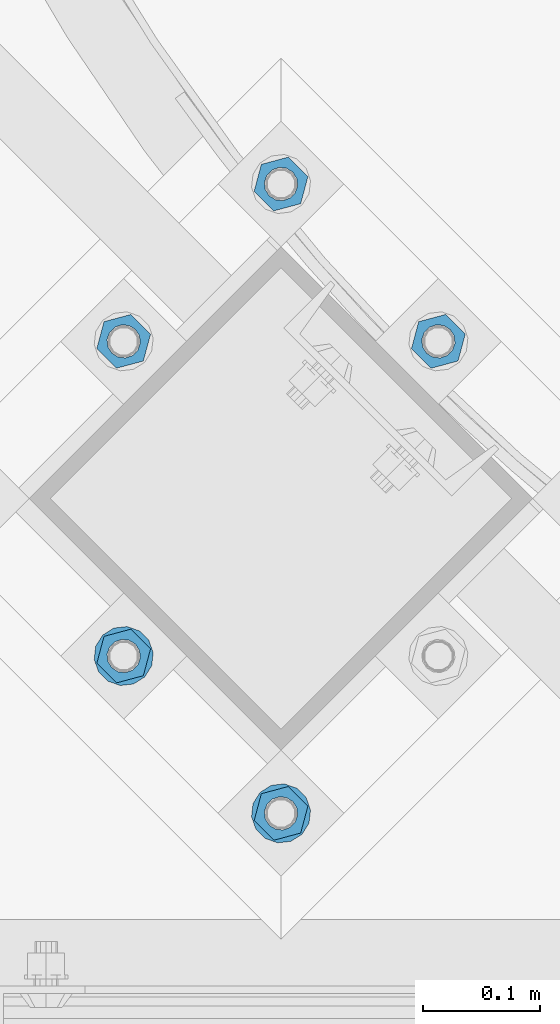
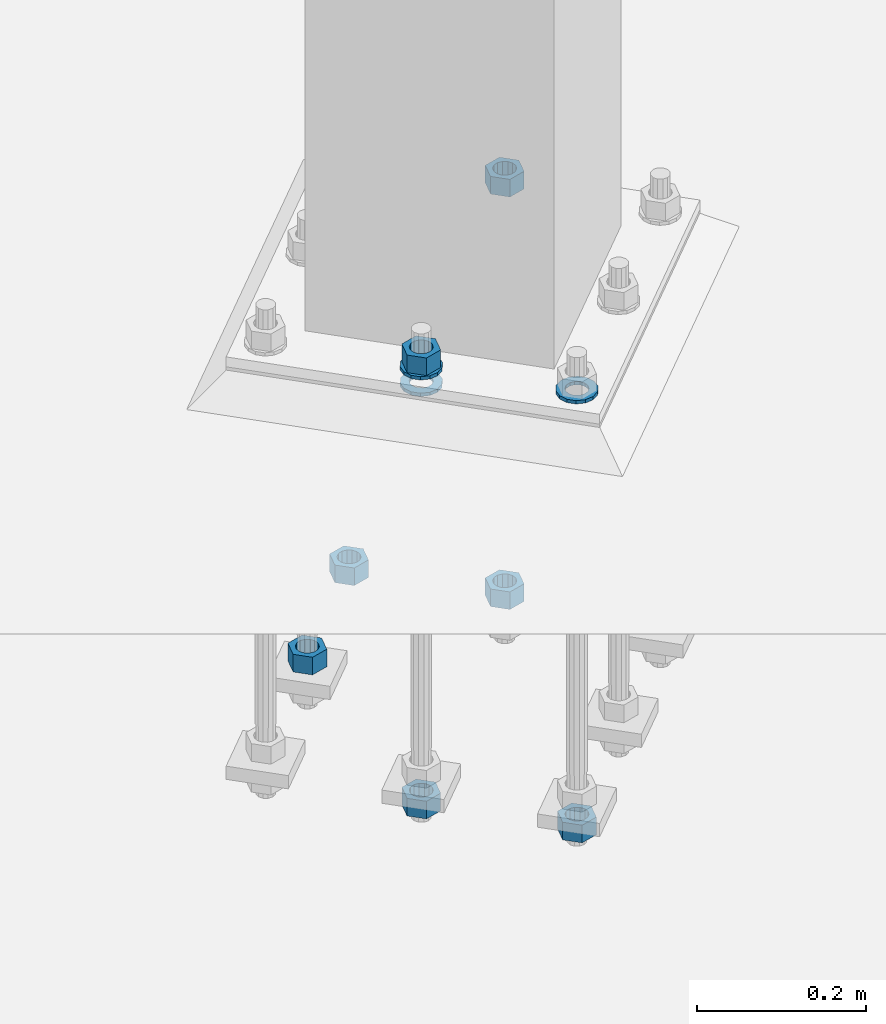
# One storey, part 863 of 1876: 10 columns, 1 element without a shape of its own.
"""IFC2X3 building model written with IfcOpenShell, lengths in millimetres."""

from ifc_helpers import new_model, si_unit, frame, origin_with_axes, place, context, subcontext, project, spatial, faceted_brep, material, type_object, element, aggregate, save


model = new_model("IFC2X3")

# Units and contexts
model_context = context("Model", 3, precision=1e-05, world=origin_with_axes())
body_context = subcontext(model_context, "Body", "Model", "MODEL_VIEW")
ifc_project = project(units=[si_unit("LENGTHUNIT", "METRE", prefix="MILLI"), si_unit("AREAUNIT", "SQUARE_METRE"), si_unit("VOLUMEUNIT", "CUBIC_METRE"), si_unit("MASSUNIT", "GRAM", prefix="KILO"), si_unit("TIMEUNIT", "SECOND"), si_unit("PLANEANGLEUNIT", "RADIAN"), si_unit("SOLIDANGLEUNIT", "STERADIAN"), si_unit("THERMODYNAMICTEMPERATUREUNIT", "DEGREE_CELSIUS"), si_unit("LUMINOUSINTENSITYUNIT", "LUMEN")], contexts=[model_context])

# Site, building, storey
site_placement = place(None, origin_with_axes())
site = spatial("IfcSite", under=ifc_project, at=site_placement, CompositionType="ELEMENT")
building_placement = place(site_placement, origin_with_axes())
building = spatial("IfcBuilding", under=site, at=building_placement, Name="Undefined", CompositionType="ELEMENT")
storey_placement = place(building_placement, origin_with_axes())
storey = spatial("IfcBuildingStorey", under=building, at=storey_placement, Name="Undefined", CompositionType="ELEMENT", Elevation=0.0)

# Assembly, columns
assembly_placement = place(storey_placement, origin_with_axes())
assembly = element("IfcElementAssembly", 1, at=assembly_placement, inside=storey, Name="TEMPLATE", AssemblyPlace="NOTDEFINED", PredefinedType="RIGID_FRAME")
ifc_material_1 = material(Name="STEEL/A563")
column_type_1 = type_object("IfcColumnType", Name="1_HEAVY_HEX_NUT", PredefinedType="NOTDEFINED")
column_1_placement = place(assembly_placement, frame((3917.62601588861, -14852.9739841119, -508.0), z_axis=(0.707106781186548, 0.707106781186547, 0.0), x_axis=(0.0, 0.0, -1.0)))
column_1 = element("IfcColumn", 2, at=column_1_placement, type_object=column_type_1, material=ifc_material_1, Name="NUT", ObjectType="1_HEAVY_HEX_NUT", context=body_context, shape_type="Brep", body=[
    faceted_brep([(0.0, -23.8099994659442, 9.09494701772928e-13), (0.0, -11.9099998474121, -20.6200008392352), (25.4, -11.9099998474157, -20.6200008392361), (25.4, -23.8099994659478, 0.0), (0.0, 11.9099998474157, -20.620000839237), (25.4, 11.9099998474121, -20.620000839237), (0.0, 23.8099994659478, 9.09494701772928e-13), (25.4, 23.8099994659442, 0.0), (0.0, 11.9099998474157, 20.620000839237), (25.4, 11.9099998474121, 20.620000839237), (0.0, -11.9099998474121, 20.6200008392389), (25.4, -11.9099998474157, 20.6200008392379), (0.0, 1.81898940354586e-12, 14.2899999618567), (0.0, 6.20019861543915, 12.8748450879584), (25.4, 6.20019861543733, 12.8748450879593), (25.4, 0.0, 14.2899999618558), (0.0, 11.1723718546473, 8.90966924477925), (25.4, 11.1723718546436, 8.90966924477925), (0.0, 13.9317198278914, 3.17982413774916), (25.4, 13.9317198278877, 3.17982413775007), (0.0, 13.9317198278914, -3.17982413774644), (25.4, 13.9317198278895, -3.17982413774735), (0.0, 11.1723718546473, -8.90966924477834), (25.4, 11.1723718546455, -8.90966924477925), (0.0, 6.20019861544279, -12.8748450879575), (25.4, 6.20019861543915, -12.8748450879584), (0.0, 3.63797880709171e-12, -14.2899999618548), (25.4, -3.63797880709171e-12, -14.2899999618548), (0.0, -6.20019861543733, -12.8748450879566), (25.4, -6.20019861544097, -12.8748450879584), (0.0, -11.1723718546455, -8.90966924477743), (25.4, -11.1723718546473, -8.90966924477834), (0.0, -13.9317198278877, -3.17982413774735), (25.4, -13.9317198278914, -3.17982413774826), (0.0, -13.9317198278895, 3.17982413774735), (25.4, -13.9317198278914, 3.17982413774826), (0.0, -11.1723718546455, 8.90966924477925), (25.4, -11.1723718546473, 8.90966924478016), (0.0, -6.20019861543915, 12.8748450879593), (25.4, -6.20019861544279, 12.8748450879593)], [[[0, 1, 2, 3]], [[1, 4, 5, 2]], [[4, 6, 7, 5]], [[6, 8, 9, 7]], [[8, 10, 11, 9]], [[10, 0, 3, 11]], [[12, 13, 14, 15]], [[13, 16, 17, 14]], [[16, 18, 19, 17]], [[18, 20, 21, 19]], [[20, 22, 23, 21]], [[22, 24, 25, 23]], [[24, 26, 27, 25]], [[26, 28, 29, 27]], [[28, 30, 31, 29]], [[30, 32, 33, 31]], [[32, 34, 35, 33]], [[34, 36, 37, 35]], [[36, 38, 39, 37]], [[38, 12, 15, 39]], [[5, 7, 9, 11, 3, 2], [17, 19, 21, 23, 25, 27, 29, 31, 33, 35, 37, 39, 15, 14]], [[10, 8, 6, 4, 1, 0], [38, 36, 34, 32, 30, 28, 26, 24, 22, 20, 18, 16, 13, 12]]]),
])
column_2_placement = place(assembly_placement, frame((3782.92217407241, -14718.2701422957, -508.0), z_axis=(-0.707106781186547, -0.707106781186548, 0.0), x_axis=(0.0, 0.0, -1.0)))
column_2 = element("IfcColumn", 3, at=column_2_placement, type_object=column_type_1, material=ifc_material_1, Name="NUT", ObjectType="1_HEAVY_HEX_NUT", context=body_context, shape_type="Brep", body=[
    faceted_brep([(0.0, -23.8099994659442, 9.09494701772928e-13), (0.0, -11.9099998474121, -20.6200008392352), (25.4, -11.9099998474157, -20.6200008392361), (25.4, -23.8099994659478, 0.0), (0.0, 11.9099998474157, -20.620000839237), (25.4, 11.9099998474121, -20.620000839237), (0.0, 23.8099994659478, 9.09494701772928e-13), (25.4, 23.8099994659442, 0.0), (0.0, 11.9099998474157, 20.620000839237), (25.4, 11.9099998474121, 20.620000839237), (0.0, -11.9099998474121, 20.6200008392389), (25.4, -11.9099998474157, 20.6200008392379), (0.0, 1.81898940354586e-12, 14.2899999618567), (0.0, 6.20019861543915, 12.8748450879584), (25.4, 6.20019861543733, 12.8748450879593), (25.4, 0.0, 14.2899999618558), (0.0, 11.1723718546473, 8.90966924477925), (25.4, 11.1723718546436, 8.90966924477925), (0.0, 13.9317198278914, 3.17982413774916), (25.4, 13.9317198278877, 3.17982413775007), (0.0, 13.9317198278914, -3.17982413774644), (25.4, 13.9317198278895, -3.17982413774735), (0.0, 11.1723718546473, -8.90966924477834), (25.4, 11.1723718546455, -8.90966924477925), (0.0, 6.20019861544279, -12.8748450879575), (25.4, 6.20019861543915, -12.8748450879584), (0.0, 3.63797880709171e-12, -14.2899999618548), (25.4, -3.63797880709171e-12, -14.2899999618548), (0.0, -6.20019861543733, -12.8748450879566), (25.4, -6.20019861544097, -12.8748450879584), (0.0, -11.1723718546455, -8.90966924477743), (25.4, -11.1723718546473, -8.90966924477834), (0.0, -13.9317198278877, -3.17982413774735), (25.4, -13.9317198278914, -3.17982413774826), (0.0, -13.9317198278895, 3.17982413774735), (25.4, -13.9317198278914, 3.17982413774826), (0.0, -11.1723718546455, 8.90966924477925), (25.4, -11.1723718546473, 8.90966924478016), (0.0, -6.20019861543915, 12.8748450879593), (25.4, -6.20019861544279, 12.8748450879593)], [[[0, 1, 2, 3]], [[1, 4, 5, 2]], [[4, 6, 7, 5]], [[6, 8, 9, 7]], [[8, 10, 11, 9]], [[10, 0, 3, 11]], [[12, 13, 14, 15]], [[13, 16, 17, 14]], [[16, 18, 19, 17]], [[18, 20, 21, 19]], [[20, 22, 23, 21]], [[22, 24, 25, 23]], [[24, 26, 27, 25]], [[26, 28, 29, 27]], [[28, 30, 31, 29]], [[30, 32, 33, 31]], [[32, 34, 35, 33]], [[34, 36, 37, 35]], [[36, 38, 39, 37]], [[38, 12, 15, 39]], [[5, 7, 9, 11, 3, 2], [17, 19, 21, 23, 25, 27, 29, 31, 33, 35, 37, 39, 15, 14]], [[10, 8, 6, 4, 1, 0], [38, 36, 34, 32, 30, 28, 26, 24, 22, 20, 18, 16, 13, 12]]]),
])
column_3_placement = place(assembly_placement, frame((3648.21833225621, -14852.9739841119, -508.0), z_axis=(-0.707106781186547, -0.707106781186548, 0.0), x_axis=(0.0, 0.0, -1.0)))
column_3 = element("IfcColumn", 4, at=column_3_placement, type_object=column_type_1, material=ifc_material_1, Name="NUT", ObjectType="1_HEAVY_HEX_NUT", context=body_context, shape_type="Brep", body=[
    faceted_brep([(0.0, -23.8099994659442, 9.09494701772928e-13), (0.0, -11.9099998474121, -20.6200008392352), (25.4, -11.9099998474157, -20.6200008392361), (25.4, -23.8099994659478, 0.0), (0.0, 11.9099998474157, -20.620000839237), (25.4, 11.9099998474121, -20.620000839237), (0.0, 23.8099994659478, 9.09494701772928e-13), (25.4, 23.8099994659442, 0.0), (0.0, 11.9099998474157, 20.620000839237), (25.4, 11.9099998474121, 20.620000839237), (0.0, -11.9099998474121, 20.6200008392389), (25.4, -11.9099998474157, 20.6200008392379), (0.0, 1.81898940354586e-12, 14.2899999618567), (0.0, 6.20019861543915, 12.8748450879584), (25.4, 6.20019861543733, 12.8748450879593), (25.4, 0.0, 14.2899999618558), (0.0, 11.1723718546473, 8.90966924477925), (25.4, 11.1723718546436, 8.90966924477925), (0.0, 13.9317198278914, 3.17982413774916), (25.4, 13.9317198278877, 3.17982413775007), (0.0, 13.9317198278914, -3.17982413774644), (25.4, 13.9317198278895, -3.17982413774735), (0.0, 11.1723718546473, -8.90966924477834), (25.4, 11.1723718546455, -8.90966924477925), (0.0, 6.20019861544279, -12.8748450879575), (25.4, 6.20019861543915, -12.8748450879584), (0.0, 3.63797880709171e-12, -14.2899999618548), (25.4, -3.63797880709171e-12, -14.2899999618548), (0.0, -6.20019861543733, -12.8748450879566), (25.4, -6.20019861544097, -12.8748450879584), (0.0, -11.1723718546455, -8.90966924477743), (25.4, -11.1723718546473, -8.90966924477834), (0.0, -13.9317198278877, -3.17982413774735), (25.4, -13.9317198278914, -3.17982413774826), (0.0, -13.9317198278895, 3.17982413774735), (25.4, -13.9317198278914, 3.17982413774826), (0.0, -11.1723718546455, 8.90966924477925), (25.4, -11.1723718546473, 8.90966924478016), (0.0, -6.20019861543915, 12.8748450879593), (25.4, -6.20019861544279, 12.8748450879593)], [[[0, 1, 2, 3]], [[1, 4, 5, 2]], [[4, 6, 7, 5]], [[6, 8, 9, 7]], [[8, 10, 11, 9]], [[10, 0, 3, 11]], [[12, 13, 14, 15]], [[13, 16, 17, 14]], [[16, 18, 19, 17]], [[18, 20, 21, 19]], [[20, 22, 23, 21]], [[22, 24, 25, 23]], [[24, 26, 27, 25]], [[26, 28, 29, 27]], [[28, 30, 31, 29]], [[30, 32, 33, 31]], [[32, 34, 35, 33]], [[34, 36, 37, 35]], [[36, 38, 39, 37]], [[38, 12, 15, 39]], [[5, 7, 9, 11, 3, 2], [17, 19, 21, 23, 25, 27, 29, 31, 33, 35, 37, 39, 15, 14]], [[10, 8, 6, 4, 1, 0], [38, 36, 34, 32, 30, 28, 26, 24, 22, 20, 18, 16, 13, 12]]]),
])
column_4_placement = place(assembly_placement, frame((3917.62601588861, -14852.9739841119, 87.3125), z_axis=(0.707106781186548, 0.707106781186547, 0.0), x_axis=(0.0, 0.0, -1.0)))
column_4 = element("IfcColumn", 5, at=column_4_placement, type_object=column_type_1, material=ifc_material_1, Name="NUT", ObjectType="1_HEAVY_HEX_NUT", context=body_context, shape_type="Brep", body=[
    faceted_brep([(0.0, -23.8099994659442, 9.09494701772928e-13), (0.0, -11.9099998474121, -20.6200008392352), (25.4, -11.9099998474157, -20.6200008392361), (25.4, -23.8099994659478, 0.0), (0.0, 11.9099998474157, -20.620000839237), (25.4, 11.9099998474121, -20.620000839237), (0.0, 23.8099994659478, 9.09494701772928e-13), (25.4, 23.8099994659442, 0.0), (0.0, 11.9099998474157, 20.620000839237), (25.4, 11.9099998474121, 20.620000839237), (0.0, -11.9099998474121, 20.6200008392389), (25.4, -11.9099998474157, 20.6200008392379), (0.0, 1.81898940354586e-12, 14.2899999618567), (0.0, 6.20019861543915, 12.8748450879584), (25.4, 6.20019861543733, 12.8748450879593), (25.4, 0.0, 14.2899999618558), (0.0, 11.1723718546473, 8.90966924477925), (25.4, 11.1723718546436, 8.90966924477925), (0.0, 13.9317198278914, 3.17982413774916), (25.4, 13.9317198278877, 3.17982413775007), (0.0, 13.9317198278914, -3.17982413774644), (25.4, 13.9317198278895, -3.17982413774735), (0.0, 11.1723718546473, -8.90966924477834), (25.4, 11.1723718546455, -8.90966924477925), (0.0, 6.20019861544279, -12.8748450879575), (25.4, 6.20019861543915, -12.8748450879584), (0.0, 3.63797880709171e-12, -14.2899999618548), (25.4, -3.63797880709171e-12, -14.2899999618548), (0.0, -6.20019861543733, -12.8748450879566), (25.4, -6.20019861544097, -12.8748450879584), (0.0, -11.1723718546455, -8.90966924477743), (25.4, -11.1723718546473, -8.90966924477834), (0.0, -13.9317198278877, -3.17982413774735), (25.4, -13.9317198278914, -3.17982413774826), (0.0, -13.9317198278895, 3.17982413774735), (25.4, -13.9317198278914, 3.17982413774826), (0.0, -11.1723718546455, 8.90966924477925), (25.4, -11.1723718546473, 8.90966924478016), (0.0, -6.20019861543915, 12.8748450879593), (25.4, -6.20019861544279, 12.8748450879593)], [[[0, 1, 2, 3]], [[1, 4, 5, 2]], [[4, 6, 7, 5]], [[6, 8, 9, 7]], [[8, 10, 11, 9]], [[10, 0, 3, 11]], [[12, 13, 14, 15]], [[13, 16, 17, 14]], [[16, 18, 19, 17]], [[18, 20, 21, 19]], [[20, 22, 23, 21]], [[22, 24, 25, 23]], [[24, 26, 27, 25]], [[26, 28, 29, 27]], [[28, 30, 31, 29]], [[30, 32, 33, 31]], [[32, 34, 35, 33]], [[34, 36, 37, 35]], [[36, 38, 39, 37]], [[38, 12, 15, 39]], [[5, 7, 9, 11, 3, 2], [17, 19, 21, 23, 25, 27, 29, 31, 33, 35, 37, 39, 15, 14]], [[10, 8, 6, 4, 1, 0], [38, 36, 34, 32, 30, 28, 26, 24, 22, 20, 18, 16, 13, 12]]]),
])
column_5_placement = place(assembly_placement, frame((3782.92217407237, -15257.0855095605, -552.45), z_axis=(0.707106781186548, 0.707106781186547, 0.0), x_axis=(0.0, 0.0, -1.0)))
column_5 = element("IfcColumn", 6, at=column_5_placement, type_object=column_type_1, material=ifc_material_1, Name="NUT", ObjectType="1_HEAVY_HEX_NUT", context=body_context, shape_type="Brep", body=[
    faceted_brep([(0.0, -23.8099994659442, 9.09494701772928e-13), (0.0, -11.9099998474121, -20.6200008392352), (25.4, -11.9099998474157, -20.6200008392361), (25.4, -23.8099994659478, 0.0), (0.0, 11.9099998474157, -20.620000839237), (25.4, 11.9099998474121, -20.620000839237), (0.0, 23.8099994659478, 9.09494701772928e-13), (25.4, 23.8099994659442, 0.0), (0.0, 11.9099998474157, 20.620000839237), (25.4, 11.9099998474121, 20.620000839237), (0.0, -11.9099998474121, 20.6200008392389), (25.4, -11.9099998474157, 20.6200008392379), (0.0, 1.81898940354586e-12, 14.2899999618567), (0.0, 6.20019861543915, 12.8748450879584), (25.4, 6.20019861543733, 12.8748450879593), (25.4, 0.0, 14.2899999618558), (0.0, 11.1723718546473, 8.90966924477925), (25.4, 11.1723718546436, 8.90966924477925), (0.0, 13.9317198278914, 3.17982413774916), (25.4, 13.9317198278877, 3.17982413775007), (0.0, 13.9317198278914, -3.17982413774644), (25.4, 13.9317198278895, -3.17982413774735), (0.0, 11.1723718546473, -8.90966924477834), (25.4, 11.1723718546455, -8.90966924477925), (0.0, 6.20019861544279, -12.8748450879575), (25.4, 6.20019861543915, -12.8748450879584), (0.0, 3.63797880709171e-12, -14.2899999618548), (25.4, -3.63797880709171e-12, -14.2899999618548), (0.0, -6.20019861543733, -12.8748450879566), (25.4, -6.20019861544097, -12.8748450879584), (0.0, -11.1723718546455, -8.90966924477743), (25.4, -11.1723718546473, -8.90966924477834), (0.0, -13.9317198278877, -3.17982413774735), (25.4, -13.9317198278914, -3.17982413774826), (0.0, -13.9317198278895, 3.17982413774735), (25.4, -13.9317198278914, 3.17982413774826), (0.0, -11.1723718546455, 8.90966924477925), (25.4, -11.1723718546473, 8.90966924478016), (0.0, -6.20019861543915, 12.8748450879593), (25.4, -6.20019861544279, 12.8748450879593)], [[[0, 1, 2, 3]], [[1, 4, 5, 2]], [[4, 6, 7, 5]], [[6, 8, 9, 7]], [[8, 10, 11, 9]], [[10, 0, 3, 11]], [[12, 13, 14, 15]], [[13, 16, 17, 14]], [[16, 18, 19, 17]], [[18, 20, 21, 19]], [[20, 22, 23, 21]], [[22, 24, 25, 23]], [[24, 26, 27, 25]], [[26, 28, 29, 27]], [[28, 30, 31, 29]], [[30, 32, 33, 31]], [[32, 34, 35, 33]], [[34, 36, 37, 35]], [[36, 38, 39, 37]], [[38, 12, 15, 39]], [[5, 7, 9, 11, 3, 2], [17, 19, 21, 23, 25, 27, 29, 31, 33, 35, 37, 39, 15, 14]], [[10, 8, 6, 4, 1, 0], [38, 36, 34, 32, 30, 28, 26, 24, 22, 20, 18, 16, 13, 12]]]),
])
column_6_placement = place(assembly_placement, frame((3648.21833225621, -15122.3816677443, 87.3125), z_axis=(0.707106781186548, 0.707106781186547, 0.0), x_axis=(0.0, 0.0, -1.0)))
column_6 = element("IfcColumn", 7, at=column_6_placement, type_object=column_type_1, material=ifc_material_1, Name="NUT", ObjectType="1_HEAVY_HEX_NUT", context=body_context, shape_type="Brep", body=[
    faceted_brep([(0.0, -23.8099994659442, 9.09494701772928e-13), (0.0, -11.9099998474121, -20.6200008392352), (25.4, -11.9099998474157, -20.6200008392361), (25.4, -23.8099994659478, 0.0), (0.0, 11.9099998474157, -20.620000839237), (25.4, 11.9099998474121, -20.620000839237), (0.0, 23.8099994659478, 9.09494701772928e-13), (25.4, 23.8099994659442, 0.0), (0.0, 11.9099998474157, 20.620000839237), (25.4, 11.9099998474121, 20.620000839237), (0.0, -11.9099998474121, 20.6200008392389), (25.4, -11.9099998474157, 20.6200008392379), (0.0, 1.81898940354586e-12, 14.2899999618567), (0.0, 6.20019861543915, 12.8748450879584), (25.4, 6.20019861543733, 12.8748450879593), (25.4, 0.0, 14.2899999618558), (0.0, 11.1723718546473, 8.90966924477925), (25.4, 11.1723718546436, 8.90966924477925), (0.0, 13.9317198278914, 3.17982413774916), (25.4, 13.9317198278877, 3.17982413775007), (0.0, 13.9317198278914, -3.17982413774644), (25.4, 13.9317198278895, -3.17982413774735), (0.0, 11.1723718546473, -8.90966924477834), (25.4, 11.1723718546455, -8.90966924477925), (0.0, 6.20019861544279, -12.8748450879575), (25.4, 6.20019861543915, -12.8748450879584), (0.0, 3.63797880709171e-12, -14.2899999618548), (25.4, -3.63797880709171e-12, -14.2899999618548), (0.0, -6.20019861543733, -12.8748450879566), (25.4, -6.20019861544097, -12.8748450879584), (0.0, -11.1723718546455, -8.90966924477743), (25.4, -11.1723718546473, -8.90966924477834), (0.0, -13.9317198278877, -3.17982413774735), (25.4, -13.9317198278914, -3.17982413774826), (0.0, -13.9317198278895, 3.17982413774735), (25.4, -13.9317198278914, 3.17982413774826), (0.0, -11.1723718546455, 8.90966924477925), (25.4, -11.1723718546473, 8.90966924478016), (0.0, -6.20019861543915, 12.8748450879593), (25.4, -6.20019861544279, 12.8748450879593)], [[[0, 1, 2, 3]], [[1, 4, 5, 2]], [[4, 6, 7, 5]], [[6, 8, 9, 7]], [[8, 10, 11, 9]], [[10, 0, 3, 11]], [[12, 13, 14, 15]], [[13, 16, 17, 14]], [[16, 18, 19, 17]], [[18, 20, 21, 19]], [[20, 22, 23, 21]], [[22, 24, 25, 23]], [[24, 26, 27, 25]], [[26, 28, 29, 27]], [[28, 30, 31, 29]], [[30, 32, 33, 31]], [[32, 34, 35, 33]], [[34, 36, 37, 35]], [[36, 38, 39, 37]], [[38, 12, 15, 39]], [[5, 7, 9, 11, 3, 2], [17, 19, 21, 23, 25, 27, 29, 31, 33, 35, 37, 39, 15, 14]], [[10, 8, 6, 4, 1, 0], [38, 36, 34, 32, 30, 28, 26, 24, 22, 20, 18, 16, 13, 12]]]),
])
column_7_placement = place(assembly_placement, frame((3648.21833225621, -15122.3816677443, -552.45), z_axis=(0.707106781186548, 0.707106781186547, 0.0), x_axis=(0.0, 0.0, -1.0)))
column_7 = element("IfcColumn", 8, at=column_7_placement, type_object=column_type_1, material=ifc_material_1, Name="NUT", ObjectType="1_HEAVY_HEX_NUT", context=body_context, shape_type="Brep", body=[
    faceted_brep([(0.0, -23.8099994659442, 9.09494701772928e-13), (0.0, -11.9099998474121, -20.6200008392352), (25.4, -11.9099998474157, -20.6200008392361), (25.4, -23.8099994659478, 0.0), (0.0, 11.9099998474157, -20.620000839237), (25.4, 11.9099998474121, -20.620000839237), (0.0, 23.8099994659478, 9.09494701772928e-13), (25.4, 23.8099994659442, 0.0), (0.0, 11.9099998474157, 20.620000839237), (25.4, 11.9099998474121, 20.620000839237), (0.0, -11.9099998474121, 20.6200008392389), (25.4, -11.9099998474157, 20.6200008392379), (0.0, 1.81898940354586e-12, 14.2899999618567), (0.0, 6.20019861543915, 12.8748450879584), (25.4, 6.20019861543733, 12.8748450879593), (25.4, 0.0, 14.2899999618558), (0.0, 11.1723718546473, 8.90966924477925), (25.4, 11.1723718546436, 8.90966924477925), (0.0, 13.9317198278914, 3.17982413774916), (25.4, 13.9317198278877, 3.17982413775007), (0.0, 13.9317198278914, -3.17982413774644), (25.4, 13.9317198278895, -3.17982413774735), (0.0, 11.1723718546473, -8.90966924477834), (25.4, 11.1723718546455, -8.90966924477925), (0.0, 6.20019861544279, -12.8748450879575), (25.4, 6.20019861543915, -12.8748450879584), (0.0, 3.63797880709171e-12, -14.2899999618548), (25.4, -3.63797880709171e-12, -14.2899999618548), (0.0, -6.20019861543733, -12.8748450879566), (25.4, -6.20019861544097, -12.8748450879584), (0.0, -11.1723718546455, -8.90966924477743), (25.4, -11.1723718546473, -8.90966924477834), (0.0, -13.9317198278877, -3.17982413774735), (25.4, -13.9317198278914, -3.17982413774826), (0.0, -13.9317198278895, 3.17982413774735), (25.4, -13.9317198278914, 3.17982413774826), (0.0, -11.1723718546455, 8.90966924477925), (25.4, -11.1723718546473, 8.90966924478016), (0.0, -6.20019861543915, 12.8748450879593), (25.4, -6.20019861544279, 12.8748450879593)], [[[0, 1, 2, 3]], [[1, 4, 5, 2]], [[4, 6, 7, 5]], [[6, 8, 9, 7]], [[8, 10, 11, 9]], [[10, 0, 3, 11]], [[12, 13, 14, 15]], [[13, 16, 17, 14]], [[16, 18, 19, 17]], [[18, 20, 21, 19]], [[20, 22, 23, 21]], [[22, 24, 25, 23]], [[24, 26, 27, 25]], [[26, 28, 29, 27]], [[28, 30, 31, 29]], [[30, 32, 33, 31]], [[32, 34, 35, 33]], [[34, 36, 37, 35]], [[36, 38, 39, 37]], [[38, 12, 15, 39]], [[5, 7, 9, 11, 3, 2], [17, 19, 21, 23, 25, 27, 29, 31, 33, 35, 37, 39, 15, 14]], [[10, 8, 6, 4, 1, 0], [38, 36, 34, 32, 30, 28, 26, 24, 22, 20, 18, 16, 13, 12]]]),
])
ifc_material_2 = material(Name="STEEL/F436")
column_type_2 = type_object("IfcColumnType", Name="1_WASHER", PredefinedType="NOTDEFINED")
column_8_placement = place(assembly_placement, frame((3782.92217407246, -15257.0855095605, 61.9125), z_axis=(0.707106781186548, 0.707106781186547, 0.0), x_axis=(0.0, 0.0, -1.0)))
column_8 = element("IfcColumn", 9, at=column_8_placement, type_object=column_type_2, material=ifc_material_2, Name="WASHER", ObjectType="1_WASHER", context=body_context, shape_type="Brep", body=[
    faceted_brep([(0.0, -25.3999996185375, 0.0), (0.0, -22.8846089010331, -11.0206468080742), (4.7625, -22.8846089010331, -11.0206468080742), (4.7625, -25.3999996185375, 0.0), (0.0, -15.8366407293743, -19.8585193564477), (4.7625, -15.8366407293743, -19.8585193564477), (0.0, -5.65203163760816, -24.7631685975166), (4.7625, -5.65203163760816, -24.7631685975166), (0.0, 5.65203163760452, -24.7631685975166), (4.7625, 5.65203163760452, -24.7631685975166), (0.0, 15.8366407293706, -19.858519356445), (4.7625, 15.8366407293706, -19.858519356445), (0.0, 22.8846089010331, -11.0206468080733), (4.7625, 22.8846089010331, -11.0206468080733), (0.0, 25.3999996185339, 9.09494701772928e-13), (4.7625, 25.3999996185339, 9.09494701772928e-13), (0.0, 22.8846089010331, 11.0206468080751), (4.7625, 22.8846089010331, 11.0206468080751), (0.0, 15.8366407293706, 19.8585193564486), (4.7625, 15.8366407293706, 19.8585193564486), (0.0, 5.65203163760452, 24.7631685975175), (4.7625, 5.65203163760452, 24.7631685975175), (0.0, -5.65203163760816, 24.7631685975175), (4.7625, -5.65203163760816, 24.7631685975175), (0.0, -15.8366407293724, 19.8585193564459), (4.7625, -15.8366407293724, 19.8585193564459), (0.0, -22.8846089010367, 11.0206468080751), (4.7625, -22.8846089010367, 11.0206468080751), (0.0, 1.81898940354586e-12, 14.2899999618567), (0.0, 6.20019861543915, 12.8748450879584), (4.7625, 6.20019861543733, 12.8748450879593), (4.7625, 0.0, 14.2899999618558), (0.0, 11.1723718546473, 8.90966924477925), (4.7625, 11.1723718546436, 8.90966924477925), (0.0, 13.9317198278914, 3.17982413774916), (4.7625, 13.9317198278877, 3.17982413775007), (0.0, 13.9317198278914, -3.17982413774644), (4.7625, 13.9317198278895, -3.17982413774735), (0.0, 11.1723718546473, -8.90966924477834), (4.7625, 11.1723718546455, -8.90966924477925), (0.0, 6.20019861544279, -12.8748450879575), (4.7625, 6.20019861543915, -12.8748450879584), (0.0, 3.63797880709171e-12, -14.2899999618548), (4.7625, -3.63797880709171e-12, -14.2899999618548), (0.0, -6.20019861543733, -12.8748450879566), (4.7625, -6.20019861544097, -12.8748450879584), (0.0, -11.1723718546455, -8.90966924477743), (4.7625, -11.1723718546473, -8.90966924477834), (0.0, -13.9317198278877, -3.17982413774735), (4.7625, -13.9317198278914, -3.17982413774826), (0.0, -13.9317198278895, 3.17982413774735), (4.7625, -13.9317198278914, 3.17982413774826), (0.0, -11.1723718546455, 8.90966924477925), (4.7625, -11.1723718546473, 8.90966924478016), (0.0, -6.20019861543915, 12.8748450879593), (4.7625, -6.20019861544279, 12.8748450879593)], [[[0, 1, 2, 3]], [[1, 4, 5, 2]], [[4, 6, 7, 5]], [[6, 8, 9, 7]], [[8, 10, 11, 9]], [[10, 12, 13, 11]], [[12, 14, 15, 13]], [[14, 16, 17, 15]], [[16, 18, 19, 17]], [[18, 20, 21, 19]], [[20, 22, 23, 21]], [[22, 24, 25, 23]], [[24, 26, 27, 25]], [[26, 0, 3, 27]], [[28, 29, 30, 31]], [[29, 32, 33, 30]], [[32, 34, 35, 33]], [[34, 36, 37, 35]], [[36, 38, 39, 37]], [[38, 40, 41, 39]], [[40, 42, 43, 41]], [[42, 44, 45, 43]], [[44, 46, 47, 45]], [[46, 48, 49, 47]], [[48, 50, 51, 49]], [[50, 52, 53, 51]], [[52, 54, 55, 53]], [[54, 28, 31, 55]], [[5, 7, 9, 11, 13, 15, 17, 19, 21, 23, 25, 27, 3, 2], [33, 35, 37, 39, 41, 43, 45, 47, 49, 51, 53, 55, 31, 30]], [[26, 24, 22, 20, 18, 16, 14, 12, 10, 8, 6, 4, 1, 0], [54, 52, 50, 48, 46, 44, 42, 40, 38, 36, 34, 32, 29, 28]]]),
])
column_9_placement = place(assembly_placement, frame((3648.21833225621, -15122.3816677442, 38.1), z_axis=(0.707106781186548, 0.707106781186547, 0.0), x_axis=(0.0, 0.0, -1.0)))
column_9 = element("IfcColumn", 10, at=column_9_placement, type_object=column_type_2, material=ifc_material_2, Name="WASHER", ObjectType="1_WASHER", context=body_context, shape_type="Brep", body=[
    faceted_brep([(0.0, -25.3999996185375, 0.0), (0.0, -22.8846089010331, -11.0206468080742), (4.7625, -22.8846089010331, -11.0206468080742), (4.7625, -25.3999996185375, 0.0), (0.0, -15.8366407293743, -19.8585193564477), (4.7625, -15.8366407293743, -19.8585193564477), (0.0, -5.65203163760816, -24.7631685975166), (4.7625, -5.65203163760816, -24.7631685975166), (0.0, 5.65203163760452, -24.7631685975166), (4.7625, 5.65203163760452, -24.7631685975166), (0.0, 15.8366407293706, -19.858519356445), (4.7625, 15.8366407293706, -19.858519356445), (0.0, 22.8846089010331, -11.0206468080733), (4.7625, 22.8846089010331, -11.0206468080733), (0.0, 25.3999996185339, 9.09494701772928e-13), (4.7625, 25.3999996185339, 9.09494701772928e-13), (0.0, 22.8846089010331, 11.0206468080751), (4.7625, 22.8846089010331, 11.0206468080751), (0.0, 15.8366407293706, 19.8585193564486), (4.7625, 15.8366407293706, 19.8585193564486), (0.0, 5.65203163760452, 24.7631685975175), (4.7625, 5.65203163760452, 24.7631685975175), (0.0, -5.65203163760816, 24.7631685975175), (4.7625, -5.65203163760816, 24.7631685975175), (0.0, -15.8366407293724, 19.8585193564459), (4.7625, -15.8366407293724, 19.8585193564459), (0.0, -22.8846089010367, 11.0206468080751), (4.7625, -22.8846089010367, 11.0206468080751), (0.0, 1.81898940354586e-12, 14.2899999618567), (0.0, 6.20019861543915, 12.8748450879584), (4.7625, 6.20019861543733, 12.8748450879593), (4.7625, 0.0, 14.2899999618558), (0.0, 11.1723718546473, 8.90966924477925), (4.7625, 11.1723718546436, 8.90966924477925), (0.0, 13.9317198278914, 3.17982413774916), (4.7625, 13.9317198278877, 3.17982413775007), (0.0, 13.9317198278914, -3.17982413774644), (4.7625, 13.9317198278895, -3.17982413774735), (0.0, 11.1723718546473, -8.90966924477834), (4.7625, 11.1723718546455, -8.90966924477925), (0.0, 6.20019861544279, -12.8748450879575), (4.7625, 6.20019861543915, -12.8748450879584), (0.0, 3.63797880709171e-12, -14.2899999618548), (4.7625, -3.63797880709171e-12, -14.2899999618548), (0.0, -6.20019861543733, -12.8748450879566), (4.7625, -6.20019861544097, -12.8748450879584), (0.0, -11.1723718546455, -8.90966924477743), (4.7625, -11.1723718546473, -8.90966924477834), (0.0, -13.9317198278877, -3.17982413774735), (4.7625, -13.9317198278914, -3.17982413774826), (0.0, -13.9317198278895, 3.17982413774735), (4.7625, -13.9317198278914, 3.17982413774826), (0.0, -11.1723718546455, 8.90966924477925), (4.7625, -11.1723718546473, 8.90966924478016), (0.0, -6.20019861543915, 12.8748450879593), (4.7625, -6.20019861544279, 12.8748450879593)], [[[0, 1, 2, 3]], [[1, 4, 5, 2]], [[4, 6, 7, 5]], [[6, 8, 9, 7]], [[8, 10, 11, 9]], [[10, 12, 13, 11]], [[12, 14, 15, 13]], [[14, 16, 17, 15]], [[16, 18, 19, 17]], [[18, 20, 21, 19]], [[20, 22, 23, 21]], [[22, 24, 25, 23]], [[24, 26, 27, 25]], [[26, 0, 3, 27]], [[28, 29, 30, 31]], [[29, 32, 33, 30]], [[32, 34, 35, 33]], [[34, 36, 37, 35]], [[36, 38, 39, 37]], [[38, 40, 41, 39]], [[40, 42, 43, 41]], [[42, 44, 45, 43]], [[44, 46, 47, 45]], [[46, 48, 49, 47]], [[48, 50, 51, 49]], [[50, 52, 53, 51]], [[52, 54, 55, 53]], [[54, 28, 31, 55]], [[5, 7, 9, 11, 13, 15, 17, 19, 21, 23, 25, 27, 3, 2], [33, 35, 37, 39, 41, 43, 45, 47, 49, 51, 53, 55, 31, 30]], [[26, 24, 22, 20, 18, 16, 14, 12, 10, 8, 6, 4, 1, 0], [54, 52, 50, 48, 46, 44, 42, 40, 38, 36, 34, 32, 29, 28]]]),
])
column_10_placement = place(assembly_placement, frame((3648.21833225621, -15122.3816677442, 61.9125), z_axis=(0.707106781186548, 0.707106781186547, 0.0), x_axis=(0.0, 0.0, -1.0)))
column_10 = element("IfcColumn", 11, at=column_10_placement, type_object=column_type_2, material=ifc_material_2, Name="WASHER", ObjectType="1_WASHER", context=body_context, shape_type="Brep", body=[
    faceted_brep([(0.0, -25.3999996185375, 0.0), (0.0, -22.8846089010331, -11.0206468080742), (4.7625, -22.8846089010331, -11.0206468080742), (4.7625, -25.3999996185375, 0.0), (0.0, -15.8366407293743, -19.8585193564477), (4.7625, -15.8366407293743, -19.8585193564477), (0.0, -5.65203163760816, -24.7631685975166), (4.7625, -5.65203163760816, -24.7631685975166), (0.0, 5.65203163760452, -24.7631685975166), (4.7625, 5.65203163760452, -24.7631685975166), (0.0, 15.8366407293706, -19.858519356445), (4.7625, 15.8366407293706, -19.858519356445), (0.0, 22.8846089010331, -11.0206468080733), (4.7625, 22.8846089010331, -11.0206468080733), (0.0, 25.3999996185339, 9.09494701772928e-13), (4.7625, 25.3999996185339, 9.09494701772928e-13), (0.0, 22.8846089010331, 11.0206468080751), (4.7625, 22.8846089010331, 11.0206468080751), (0.0, 15.8366407293706, 19.8585193564486), (4.7625, 15.8366407293706, 19.8585193564486), (0.0, 5.65203163760452, 24.7631685975175), (4.7625, 5.65203163760452, 24.7631685975175), (0.0, -5.65203163760816, 24.7631685975175), (4.7625, -5.65203163760816, 24.7631685975175), (0.0, -15.8366407293724, 19.8585193564459), (4.7625, -15.8366407293724, 19.8585193564459), (0.0, -22.8846089010367, 11.0206468080751), (4.7625, -22.8846089010367, 11.0206468080751), (0.0, 1.81898940354586e-12, 14.2899999618567), (0.0, 6.20019861543915, 12.8748450879584), (4.7625, 6.20019861543733, 12.8748450879593), (4.7625, 0.0, 14.2899999618558), (0.0, 11.1723718546473, 8.90966924477925), (4.7625, 11.1723718546436, 8.90966924477925), (0.0, 13.9317198278914, 3.17982413774916), (4.7625, 13.9317198278877, 3.17982413775007), (0.0, 13.9317198278914, -3.17982413774644), (4.7625, 13.9317198278895, -3.17982413774735), (0.0, 11.1723718546473, -8.90966924477834), (4.7625, 11.1723718546455, -8.90966924477925), (0.0, 6.20019861544279, -12.8748450879575), (4.7625, 6.20019861543915, -12.8748450879584), (0.0, 3.63797880709171e-12, -14.2899999618548), (4.7625, -3.63797880709171e-12, -14.2899999618548), (0.0, -6.20019861543733, -12.8748450879566), (4.7625, -6.20019861544097, -12.8748450879584), (0.0, -11.1723718546455, -8.90966924477743), (4.7625, -11.1723718546473, -8.90966924477834), (0.0, -13.9317198278877, -3.17982413774735), (4.7625, -13.9317198278914, -3.17982413774826), (0.0, -13.9317198278895, 3.17982413774735), (4.7625, -13.9317198278914, 3.17982413774826), (0.0, -11.1723718546455, 8.90966924477925), (4.7625, -11.1723718546473, 8.90966924478016), (0.0, -6.20019861543915, 12.8748450879593), (4.7625, -6.20019861544279, 12.8748450879593)], [[[0, 1, 2, 3]], [[1, 4, 5, 2]], [[4, 6, 7, 5]], [[6, 8, 9, 7]], [[8, 10, 11, 9]], [[10, 12, 13, 11]], [[12, 14, 15, 13]], [[14, 16, 17, 15]], [[16, 18, 19, 17]], [[18, 20, 21, 19]], [[20, 22, 23, 21]], [[22, 24, 25, 23]], [[24, 26, 27, 25]], [[26, 0, 3, 27]], [[28, 29, 30, 31]], [[29, 32, 33, 30]], [[32, 34, 35, 33]], [[34, 36, 37, 35]], [[36, 38, 39, 37]], [[38, 40, 41, 39]], [[40, 42, 43, 41]], [[42, 44, 45, 43]], [[44, 46, 47, 45]], [[46, 48, 49, 47]], [[48, 50, 51, 49]], [[50, 52, 53, 51]], [[52, 54, 55, 53]], [[54, 28, 31, 55]], [[5, 7, 9, 11, 13, 15, 17, 19, 21, 23, 25, 27, 3, 2], [33, 35, 37, 39, 41, 43, 45, 47, 49, 51, 53, 55, 31, 30]], [[26, 24, 22, 20, 18, 16, 14, 12, 10, 8, 6, 4, 1, 0], [54, 52, 50, 48, 46, 44, 42, 40, 38, 36, 34, 32, 29, 28]]]),
])
aggregate(assembly, [column_1, column_2, column_3, column_4, column_8, column_5, column_6, column_9, column_10, column_7])

save(model, "model.ifc")
